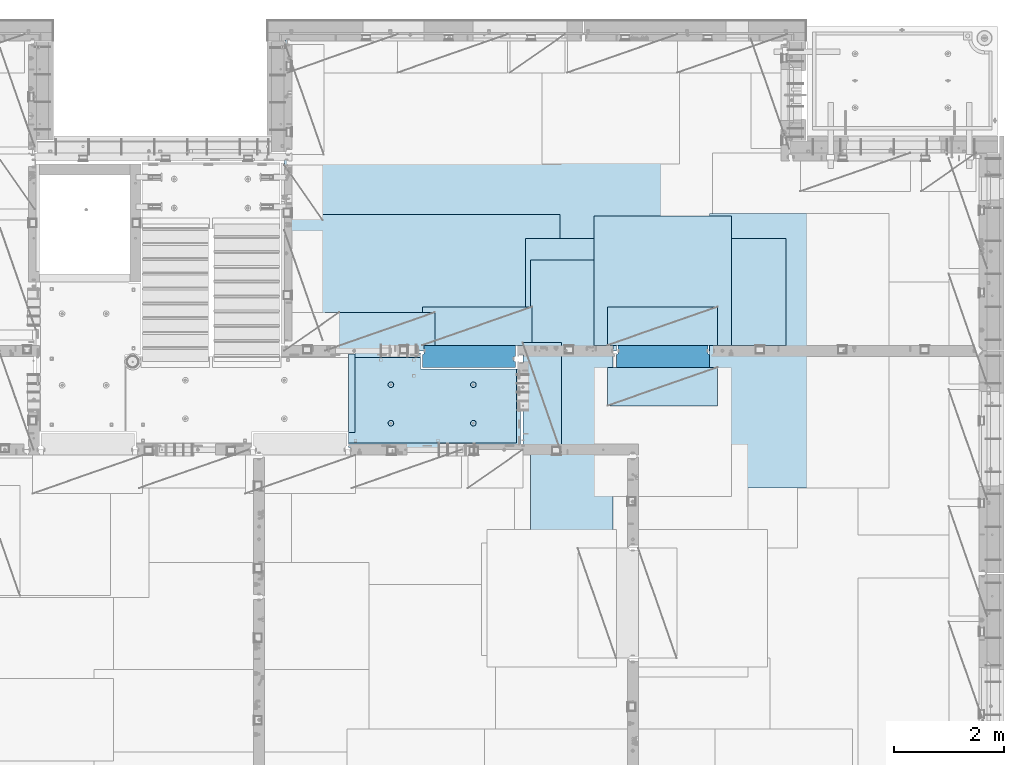
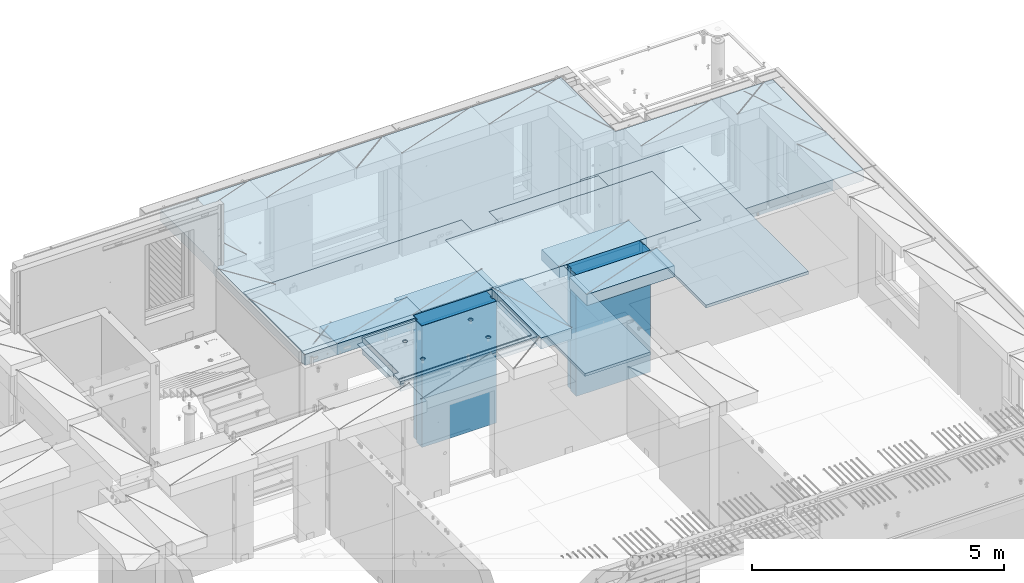
# One storey, part 209 of 349: 12 plates, 2 slabs, 13 elements without a shape of their own.
"""IFC2X3 building model written with IfcOpenShell, lengths in millimetres."""

from ifc_helpers import new_model, si_unit, frame, origin_with_axes, place, context, subcontext, project, spatial, faceted_brep, material, type_object, element, aggregate, save


model = new_model("IFC2X3")

# Units and contexts
model_context = context("Model", 3, precision=1e-05, world=origin_with_axes())
body_context = subcontext(model_context, "Body", "Model", "MODEL_VIEW")
ifc_project = project(units=[si_unit("LENGTHUNIT", "METRE", prefix="MILLI"), si_unit("AREAUNIT", "SQUARE_METRE"), si_unit("VOLUMEUNIT", "CUBIC_METRE"), si_unit("MASSUNIT", "GRAM", prefix="KILO"), si_unit("TIMEUNIT", "SECOND"), si_unit("PLANEANGLEUNIT", "RADIAN"), si_unit("SOLIDANGLEUNIT", "STERADIAN"), si_unit("THERMODYNAMICTEMPERATUREUNIT", "DEGREE_CELSIUS"), si_unit("LUMINOUSINTENSITYUNIT", "LUMEN")], contexts=[model_context])

# Site, building, storey
site_placement = place(None, origin_with_axes())
site = spatial("IfcSite", under=ifc_project, at=site_placement, CompositionType="ELEMENT")
building_placement = place(site_placement, origin_with_axes())
building = spatial("IfcBuilding", under=site, at=building_placement, CompositionType="ELEMENT")
storey_placement = place(building_placement, origin_with_axes())
storey = spatial("IfcBuildingStorey", under=building, at=storey_placement, Name="4", CompositionType="ELEMENT", Elevation=0.0)

# Assembly, slab
assembly_1_placement = place(storey_placement, origin_with_axes())
assembly_1 = element("IfcElementAssembly", 1, at=assembly_1_placement, inside=storey, AssemblyPlace="NOTDEFINED", PredefinedType="REINFORCEMENT_UNIT")
ifc_material_1 = material(Name="CONCRETE/C25/30")
slab_type_1 = type_object("IfcSlabType", PredefinedType="NOTDEFINED")
slab_1_placement = place(assembly_1_placement, frame((26570.0059390845, 15220.0026483125, 93620.0), z_axis=(-0.999999999997437, -2.26400000064461e-06, 0.0), x_axis=(-1.19799915409591e-06, 0.999999999999282, 0.0)))
slab_1 = element("IfcSlab", 2, at=slab_1_placement, type_object=slab_type_1, material=ifc_material_1, PredefinedType="FLOOR", context=body_context, shape_type="Brep", body=[
    faceted_brep([(260.000036693442, 30.0, 20.0001116859203), (260.00040878505, 30.0, 210.00282380305), (760.000392750888, 30.0, 210.001882803081), (760.000035167954, 30.0, 20.0003241859195), (259.999997532928, 50.0008466322761, 0.000110715616756352), (259.999997531775, 130.0, 4.72937244921923e-11), (260.00040878505, 130.0, 210.00282380305), (260.00003669344, 50.0008466322906, 20.0001116859239), (760.000392750888, 130.0, 210.001882803081), (759.999997530887, 50.0009701322706, 0.00188280345173553), (760.000035167954, 50.0009701322851, 20.0003241859267), (759.999997530887, 130.0, 1.4915713109076e-10), (0.0, 130.0, -1.81898940354586e-12), (0.0, 50.0007830199902, -3.63797880709171e-12), (2.23492861550767e-06, 50.0007830199902, 20.0000012144774), (0.00314200731554592, 50.0009709416772, 1679.99820316408), (0.00316042736994859, 130.0, 1679.99820316404), (20.0042037197236, 50.0007871208509, 20.0000019346335), (20.0050448999082, 50.0009732451872, 1679.9981655205), (20.0051981998968, 30.0, 1979.99816552074), (210.003723882246, 30.0, 1979.99780794351), (210.003159282247, 30.0, 1679.99780794404), (20.0050448999027, 30.0, 1679.9981655205), (20.0057858500695, 50.0011356208415, 3129.99855788155), (0.00588817475545511, 50.0011356208415, 3129.99536132812), (0.00371018100122456, 50.0010050132987, 1979.99820316354), (20.0051981998986, 50.0010068401461, 1979.99816552074), (1720.00727399273, -49.9988643791585, 3014.99216831216), (1700.0058891816, -49.9988643791585, 3014.99217713277), (1700.0058891816, 9.99999999994179, 3014.99217713277), (270.007273993393, 9.99999999994179, 3014.99280776216), (270.007273993393, -130.000000000058, 3014.99280776216), (1640.00591170533, -130.000000000058, 3014.99220359276), (1640.00591170533, -110.000000000058, 3014.99220359276), (1720.00727399273, -110.000000000058, 3014.99216831216), (1700.00578510373, 9.99999999994179, 3129.99536132812), (270.007324709519, 9.99999999994179, 3129.99536132812), (1700.00588013352, 9.99999999994179, 3024.99005271558), (270.007324709519, -130.0, 3129.99536132812), (0.0, -49.9992169800098, -3.63797880709171e-12), (1.81898940354586e-12, -110.000000000058, 0.0), (0.00588817475545511, -110.0, 3129.99536132812), (0.00588817475545511, -49.9988643791585, 3129.99536132812), (2.27349282795331e-05, -49.9992169800098, 20.000001214441), (40.0000000237706, -110.0, 0.00323799208854325), (40.0000056179106, -110.0, 80.000116817555), (80.0001648500238, -110.0, 80.0001140175445), (80.0058896111077, -110.0, 3129.99536132811), (80.0001648500238, -130.0, 80.0001140175445), (80.0058896111077, -130.0, 3129.99536132812), (458.262860973307, -110.000000000015, 813.90255309167), (472.201273869185, -110.000000000015, 821.004529187678), (483.262860973307, -110.000000000015, 832.066116291804), (490.364837069317, -110.000000000015, 846.004529187678), (492.812011254558, -110.000000000015, 861.455378906427), (490.364837069317, -110.000000000015, 876.906228625172), (483.262860973307, -110.000000000015, 890.844641521049), (472.201273869185, -110.000000000015, 901.906228625176), (458.262860973306, -110.000000000015, 909.008204721184), (442.81201125456, -110.000000000015, 911.455378906427), (427.361161535811, -110.000000000015, 909.008204721184), (413.422748639936, -110.000000000015, 901.906228625176), (402.361161535813, -110.000000000015, 890.844641521046), (395.259185439802, -110.000000000015, 876.906228625176), (392.81201125456, -110.000000000015, 861.455378906427), (395.259185439802, -110.000000000015, 846.004529187681), (402.361161535813, -110.000000000015, 832.0661162918), (413.422748639936, -110.000000000015, 821.004529187678), (427.361161535813, -110.000000000015, 813.90255309167), (442.812011254558, -110.000000000015, 811.455378906427), (458.965172324157, -130.0, 811.741061009179), (442.812011254558, -130.0, 809.182651633699), (473.537149442574, -130.0, 819.165854200462), (485.101535960521, -130.0, 830.730240718414), (492.526329151806, -130.0, 845.302217836826), (495.084738527285, -130.0, 861.45537890643), (492.526329151804, -130.0, 877.608539976027), (485.101535960521, -130.0, 892.180517094443), (473.537149442574, -130.0, 903.744903612387), (458.965172324157, -130.0, 911.16969680367), (442.81201125456, -130.0, 913.728106179151), (426.658850184962, -130.0, 911.169696803674), (412.086873066544, -130.0, 903.744903612391), (400.522486548598, -130.0, 892.180517094443), (393.097693357315, -130.0, 877.608539976027), (390.539283981834, -130.0, 861.455378906427), (393.097693357317, -130.0, 845.302217836826), (400.522486548598, -130.0, 830.730240718414), (412.086873066544, -130.0, 819.165854200462), (426.658850184962, -130.0, 811.741061009183), (1158.26361347154, -110.000000000058, 2313.90608356011), (1172.20202636741, -110.000000000058, 2321.00805965612), (1183.26361347154, -110.000000000058, 2332.06964676024), (1190.36558956755, -110.000000000058, 2346.00805965611), (1192.81276375279, -110.000000000058, 2361.45890937486), (1190.36558956755, -110.000000000058, 2376.90975909361), (1183.26361347154, -110.000000000058, 2390.84817198949), (1172.20202636741, -110.000000000058, 2401.90975909361), (1158.26361347154, -110.000000000058, 2409.01173518962), (1142.81276375279, -110.000000000058, 2411.45890937487), (1127.36191403404, -110.000000000058, 2409.01173518962), (1113.42350113817, -110.000000000058, 2401.90975909361), (1102.36191403404, -110.000000000058, 2390.84817198948), (1095.25993793803, -110.000000000058, 2376.90975909361), (1092.81276375279, -110.000000000058, 2361.45890937486), (1095.25993793803, -110.000000000058, 2346.00805965612), (1102.36191403404, -110.000000000058, 2332.06964676024), (1113.42350113817, -110.000000000058, 2321.00805965611), (1127.36191403405, -110.000000000058, 2313.90608356011), (1142.81276375279, -110.000000000058, 2311.45890937486), (1158.96592482239, -130.000000000044, 2311.74459147762), (1142.81276375279, -130.000000000044, 2309.18618210214), (1173.5379019408, -130.000000000044, 2319.1693846689), (1185.10228845875, -130.000000000044, 2330.73377118685), (1192.52708165004, -130.000000000044, 2345.30574830526), (1195.08549102551, -130.000000000044, 2361.45890937486), (1192.52708165004, -130.000000000044, 2377.61207044447), (1185.10228845875, -130.000000000044, 2392.18404756288), (1173.5379019408, -130.000000000044, 2403.74843408083), (1158.96592482239, -130.000000000044, 2411.17322727211), (1142.81276375279, -130.000000000044, 2413.73163664759), (1126.65960268319, -130.000000000044, 2411.17322727211), (1112.08762556478, -130.000000000044, 2403.74843408083), (1100.52323904683, -130.000000000044, 2392.18404756287), (1093.09844585554, -130.000000000044, 2377.61207044447), (1090.54003648007, -130.000000000044, 2361.45890937486), (1093.09844585555, -130.000000000044, 2345.30574830526), (1100.52323904683, -130.000000000044, 2330.73377118685), (1112.08762556478, -130.000000000044, 2319.1693846689), (1126.65960268319, -130.000000000044, 2311.74459147762), (1158.26322681425, -110.000000000029, 813.902566246979), (1172.20163971013, -110.000000000029, 821.004542342987), (1183.26322681425, -110.000000000029, 832.066129447114), (1190.36520291026, -110.000000000029, 846.004542342987), (1192.8123770955, -110.000000000029, 861.455392061736), (1190.36520291026, -110.000000000029, 876.906241780482), (1183.26322681425, -110.000000000029, 890.844654676363), (1172.20163971012, -110.000000000029, 901.906241780485), (1158.26322681425, -110.000000000029, 909.008217876493), (1142.8123770955, -110.000000000029, 911.455392061736), (1127.36152737675, -110.000000000029, 909.008217876493), (1113.42311448088, -110.000000000029, 901.906241780485), (1102.36152737675, -110.000000000029, 890.844654676359), (1095.25955128074, -110.000000000029, 876.906241780485), (1092.8123770955, -110.000000000029, 861.45539206174), (1095.25955128074, -110.000000000029, 846.004542342991), (1102.36152737675, -110.000000000029, 832.06612944711), (1113.42311448088, -110.000000000029, 821.004542342987), (1127.36152737675, -110.000000000029, 813.902566246979), (1142.8123770955, -110.000000000029, 811.455392061736), (1158.9655381651, -130.000000000029, 811.741074164489), (1142.8123770955, -130.000000000029, 809.182664789012), (1173.53751528352, -130.000000000029, 819.165867355772), (1185.10190180146, -130.000000000029, 830.730253873724), (1192.52669499275, -130.000000000029, 845.302230992136), (1195.08510436823, -130.000000000029, 861.45539206174), (1192.52669499275, -130.000000000029, 877.608553131337), (1185.10190180146, -130.000000000029, 892.180530249756), (1173.53751528351, -130.000000000029, 903.744916767697), (1158.9655381651, -130.000000000029, 911.16970995898), (1142.8123770955, -130.000000000029, 913.728119334461), (1126.6592160259, -130.000000000029, 911.169709958984), (1112.08723890749, -130.000000000029, 903.7449167677), (1100.52285238954, -130.000000000029, 892.180530249752), (1093.09805919825, -130.000000000029, 877.608553131337), (1090.53964982277, -130.000000000015, 861.455392061736), (1093.09805919826, -130.000000000015, 845.302230992136), (1100.52285238954, -130.000000000015, 830.730253873724), (1112.08723890749, -130.000000000015, 819.165867355776), (1126.6592160259, -130.000000000015, 811.741074164493), (458.263613472778, -110.000000000058, 2313.90740096011), (472.202026368655, -110.000000000058, 2321.00937705611), (483.263613472776, -110.000000000058, 2332.07096416024), (490.365589568788, -110.000000000058, 2346.00937705611), (492.812763754029, -110.000000000058, 2361.46022677486), (490.365589568788, -110.000000000058, 2376.91107649361), (483.263613472778, -110.000000000058, 2390.84948938949), (472.202026368655, -110.000000000058, 2401.91107649361), (458.263613472776, -110.000000000058, 2409.01305258962), (442.812763754029, -110.000000000058, 2411.46022677486), (427.361914035282, -110.000000000058, 2409.01305258962), (413.423501139407, -110.000000000058, 2401.91107649361), (402.361914035284, -110.000000000058, 2390.84948938949), (395.259937939272, -110.000000000058, 2376.91107649361), (392.812763754031, -110.000000000058, 2361.46022677486), (395.259937939272, -110.000000000058, 2346.00937705612), (402.361914035284, -110.000000000058, 2332.07096416024), (413.423501139407, -110.000000000058, 2321.00937705611), (427.361914035284, -110.000000000058, 2313.90740096011), (442.812763754029, -110.000000000058, 2311.46022677486), (458.965924823628, -130.000000000029, 2311.74590887762), (442.812763754029, -130.000000000029, 2309.18749950214), (473.537901942043, -130.000000000029, 2319.1707020689), (485.10228845999, -130.000000000029, 2330.73508858685), (492.527081651273, -130.000000000029, 2345.30706570526), (495.085491026754, -130.000000000029, 2361.46022677486), (492.527081651273, -130.000000000029, 2377.61338784446), (485.102288459992, -130.000000000029, 2392.18536496288), (473.537901942043, -130.000000000029, 2403.74975148082), (458.965924823628, -130.000000000029, 2411.1745446721), (442.812763754031, -130.000000000029, 2413.73295404758), (426.659602684433, -130.000000000029, 2411.17454467211), (412.087625566017, -130.000000000029, 2403.74975148082), (400.523239048071, -130.000000000029, 2392.18536496288), (393.098445856787, -130.000000000029, 2377.61338784446), (390.540036481307, -130.000000000029, 2361.46022677486), (393.098445856789, -130.000000000029, 2345.30706570526), (400.523239048067, -130.000000000029, 2330.73508858685), (412.087625566017, -130.000000000029, 2319.17070206891), (426.659602684433, -130.000000000029, 2311.74590887762), (1640.0069692709, -130.000000000058, 1820.00285259458), (1429.99412576448, -130.0, 80.0005450159842), (1430.00077693619, -130.000000000044, 1820.00324782623), (1640.0069692709, -110.000000000058, 1820.00285259458), (1720.00719314726, -110.000000000058, 1820.00270203416), (1720.00719416424, -49.9988643791585, 1820.00270203415), (1700.00697064704, -49.9988643791585, 1820.00273967458), (1430.00077693619, 129.999999999985, 1820.00324782623), (1720.00507313573, 130.0, 1820.00270203815), (1720.00696350816, 50.0011356208415, 1820.00270203459), (1700.00697064704, 50.0011356208415, 1820.00273967458), (1720.00548380367, 130.0, 2629.9953613439), (1720.00479630696, 50.0011356208415, 2629.99536134425), (1700.00623760369, 50.0011356208415, 2629.99539898154), (1700.00623760369, 30.0, 2629.99539898154), (1700.00578510373, 30.0, 3129.99535793147), (1510.00479630733, 130.0, 2629.99575656425), (1510.00479630733, 30.0, 2629.99575656425), (1510.00573730659, 130.0, 3129.99536132812), (1510.00573730659, 30.0, 3129.99536134176), (0.00588817475545511, 130.0, 3129.99536132812), (20.0057858500695, -49.9988643791585, 3129.99855788155), (0.00372479000361636, 130.0, 1979.99820316351), (210.003723882246, 130.0, 1979.99780794351), (210.003159282247, 130.0, 1679.99780794404), (20.0042037196527, -49.9988643791585, 20.0000019345935), (20.0041864226587, -49.9992128791491, 7.34271452529356e-07), (1429.99419217423, -49.9988643791585, 20.0006089333838), (1429.99420067423, -49.9988643791585, 0.000608933383773547), (80.0000146155362, -110.0, 0.000114017555461032), (1429.99735169022, -110.0, 7.40013310860377e-05), (1429.99412576448, -110.0, 80.0005450159842), (1429.99416747423, 50.0011356208415, 20.0006089334311), (1429.99417597423, 50.0011356208415, 0.000608933431067271), (1429.99735169022, 130.0, 2.80124368146062e-10), (20.0041864225386, 50.0007871208509, -3.03407432511449e-09)], [[[0, 1, 2, 3]], [[4, 5, 6, 1, 0, 7]], [[8, 2, 1, 6]], [[9, 10, 3, 2, 8, 11]], [[12, 13, 14, 15, 16]], [[14, 17, 18, 15]], [[19, 20, 21, 22]], [[23, 24, 25, 26]], [[27, 28, 29, 30, 31, 32, 33, 34]], [[35, 36, 30, 29, 37]], [[31, 30, 36, 38]], [[39, 40, 41, 42, 43]], [[44, 45, 46, 47, 41, 40]], [[48, 49, 47, 46]], [[50, 51, 52, 53, 54, 55, 56, 57, 58, 59, 60, 61, 62, 63, 64, 65, 66, 67, 68, 69]], [[70, 50, 69, 71]], [[72, 51, 50, 70]], [[73, 52, 51, 72]], [[74, 53, 52, 73]], [[75, 54, 53, 74]], [[76, 55, 54, 75]], [[77, 56, 55, 76]], [[78, 57, 56, 77]], [[79, 58, 57, 78]], [[80, 59, 58, 79]], [[81, 60, 59, 80]], [[82, 61, 60, 81]], [[83, 62, 61, 82]], [[84, 63, 62, 83]], [[85, 64, 63, 84]], [[86, 65, 64, 85]], [[87, 66, 65, 86]], [[88, 67, 66, 87]], [[89, 68, 67, 88]], [[71, 69, 68, 89]], [[90, 91, 92, 93, 94, 95, 96, 97, 98, 99, 100, 101, 102, 103, 104, 105, 106, 107, 108, 109]], [[110, 90, 109, 111]], [[112, 91, 90, 110]], [[113, 92, 91, 112]], [[114, 93, 92, 113]], [[115, 94, 93, 114]], [[116, 95, 94, 115]], [[117, 96, 95, 116]], [[118, 97, 96, 117]], [[119, 98, 97, 118]], [[120, 99, 98, 119]], [[121, 100, 99, 120]], [[122, 101, 100, 121]], [[123, 102, 101, 122]], [[124, 103, 102, 123]], [[125, 104, 103, 124]], [[126, 105, 104, 125]], [[127, 106, 105, 126]], [[128, 107, 106, 127]], [[129, 108, 107, 128]], [[111, 109, 108, 129]], [[130, 131, 132, 133, 134, 135, 136, 137, 138, 139, 140, 141, 142, 143, 144, 145, 146, 147, 148, 149]], [[150, 130, 149, 151]], [[152, 131, 130, 150]], [[153, 132, 131, 152]], [[154, 133, 132, 153]], [[155, 134, 133, 154]], [[156, 135, 134, 155]], [[157, 136, 135, 156]], [[158, 137, 136, 157]], [[159, 138, 137, 158]], [[160, 139, 138, 159]], [[161, 140, 139, 160]], [[162, 141, 140, 161]], [[163, 142, 141, 162]], [[164, 143, 142, 163]], [[165, 144, 143, 164]], [[166, 145, 144, 165]], [[167, 146, 145, 166]], [[168, 147, 146, 167]], [[169, 148, 147, 168]], [[151, 149, 148, 169]], [[170, 171, 172, 173, 174, 175, 176, 177, 178, 179, 180, 181, 182, 183, 184, 185, 186, 187, 188, 189]], [[190, 170, 189, 191]], [[192, 171, 170, 190]], [[193, 172, 171, 192]], [[194, 173, 172, 193]], [[195, 174, 173, 194]], [[196, 175, 174, 195]], [[197, 176, 175, 196]], [[198, 177, 176, 197]], [[199, 178, 177, 198]], [[200, 179, 178, 199]], [[201, 180, 179, 200]], [[202, 181, 180, 201]], [[203, 182, 181, 202]], [[204, 183, 182, 203]], [[205, 184, 183, 204]], [[206, 185, 184, 205]], [[207, 186, 185, 206]], [[208, 187, 186, 207]], [[209, 188, 187, 208]], [[191, 189, 188, 209]], [[210, 32, 31, 38, 49, 48, 211, 212], [208, 207, 206, 205, 204, 203, 202, 201, 200, 199, 198, 197, 196, 195, 194, 193, 192, 190, 191, 209], [168, 167, 166, 165, 164, 163, 162, 161, 160, 159, 158, 157, 156, 155, 154, 153, 152, 150, 151, 169], [128, 127, 126, 125, 124, 123, 122, 121, 120, 119, 118, 117, 116, 115, 114, 113, 112, 110, 111, 129], [88, 87, 86, 85, 84, 83, 82, 81, 80, 79, 78, 77, 76, 75, 74, 73, 72, 70, 71, 89]], [[33, 32, 210, 213]], [[34, 33, 213, 214]], [[27, 34, 214, 215]], [[28, 27, 215, 216]], [[214, 213, 210, 212, 217, 218, 219, 220, 216, 215]], [[219, 218, 221, 222]], [[220, 219, 222, 223]], [[35, 37, 29, 28, 216, 220, 223, 224, 225]], [[222, 221, 226, 227, 224, 223]], [[228, 229, 227, 226]], [[224, 227, 229, 225]], [[228, 230, 24, 23, 231, 42, 41, 47, 49, 38, 36, 35, 225, 229]], [[24, 230, 232, 25]], [[233, 20, 19, 26, 25, 232]], [[234, 21, 20, 233]], [[16, 15, 18, 22, 21, 234]], [[17, 235, 231, 23, 26, 19, 22, 18]], [[43, 42, 231, 235]], [[236, 39, 43, 235, 237, 238]], [[239, 44, 40, 39, 236, 238, 240]], [[46, 45, 44, 239, 240, 241]], [[48, 46, 241, 211]], [[240, 238, 237, 242, 243, 244, 217, 212, 211, 241]], [[244, 243, 9, 11]], [[6, 5, 12, 16, 234, 233, 232, 230, 228, 226, 221, 218, 217, 244, 11, 8]], [[245, 13, 12, 5, 4]], [[17, 14, 13, 245, 4, 7]], [[242, 237, 235, 17, 7, 0, 3, 10]], [[243, 242, 10, 9]]]),
])
aggregate(assembly_1, [slab_1])

assembly_2_placement = place(storey_placement, origin_with_axes())
assembly_2 = element("IfcElementAssembly", 3, at=assembly_2_placement, inside=storey, AssemblyPlace="NOTDEFINED", PredefinedType="REINFORCEMENT_UNIT")
ifc_material_2 = material(Name="CONCRETE/C30/37")
slab_type_2 = type_object("IfcSlabType", PredefinedType="NOTDEFINED")
slab_2_placement = place(assembly_2_placement, frame((22310.0, 16980.0, 93595.0), z_axis=(0.0, 1.0, 0.0), x_axis=(1.0, 0.0, 0.0)))
slab_2 = element("IfcSlab", 4, at=slab_2_placement, type_object=slab_type_2, material=ifc_material_2, PredefinedType="FLOOR", context=body_context, shape_type="Brep", body=[
    faceted_brep([(4369.99914550782, -135.0, 99.9999987875526), (4369.99914550782, 135.0, 99.9999987875526), (4369.99914550782, 135.0, 0.0), (4369.99914550782, -135.0, 0.0), (4169.99914550781, -135.0, 99.9997253417969), (4169.99914550781, 135.0, 99.9997253417969), (2489.99914550781, -135.0, 0.0), (2489.99914550781, 135.0, 0.0), (2489.99914550781, 135.0, 99.9997253417969), (2489.99914550781, -135.0, 99.9997253417969), (1.81898940354586e-12, -135.0, 1.81898940354586e-12), (1.81898940354586e-12, 135.0, 1.81898940354586e-12), (-39.9985427856445, -135.0, -0.0037095642182976), (-39.9985427856445, 135.0, -0.0037095642182976), (-40.0, -135.0, 3600.00048828125), (-40.0, 135.0, 3600.00048828125), (-20.0, -135.0, 3600.0), (-20.0, 135.0, 3600.0), (-20.0, -135.0, 5760.0), (-20.0, 135.0, 5760.0), (9149.9990234375, -135.0, 5760.0), (9149.9990234375, 135.0, 5760.0), (9149.9990234375, -135.0, 3600.00073242188), (9149.9990234375, 135.0, 3600.00073242188), (12750.0, -135.0, 3599.9951171875), (12750.0, 135.0, 3599.9951171875), (12750.0, -135.0, 0.0), (12750.0, 135.0, 0.0), (7685.0006429507, -135.0, 0.0), (7685.0006429507, 135.0, 0.0), (7685.0006429507, -135.0, 99.9996630941932), (7685.0006429507, 135.0, 99.9996630941932), (5999.99954431789, -135.0, 99.9996630941932), (5999.99954431789, 135.0, 99.9996630941932), (5999.99954431789, -135.0, 0.0), (5999.99954431789, 135.0, 0.0), (2730.00000000001, 135.0, 99.9997253417969), (2730.00000000001, -135.0, 99.9997253417969)], [[[0, 1, 2, 3]], [[4, 5, 1, 0]], [[6, 7, 8, 9]], [[10, 11, 7, 6]], [[10, 12, 13, 11]], [[12, 14, 15, 13]], [[14, 16, 17, 15]], [[16, 18, 19, 17]], [[18, 20, 21, 19]], [[20, 22, 23, 21]], [[22, 24, 25, 23]], [[24, 26, 27, 25]], [[27, 26, 28, 29]], [[30, 31, 29, 28]], [[32, 33, 31, 30]], [[34, 35, 33, 32]], [[35, 34, 3, 2]], [[36, 8, 7, 11, 13, 15, 17, 19, 21, 23, 25, 27, 29, 31, 33, 35, 2, 1, 5]], [[37, 9, 8, 36, 5, 4]], [[34, 32, 30, 28, 26, 24, 22, 20, 18, 16, 14, 12, 10, 6, 9, 37, 4, 0, 3]]]),
])

# Assembly, plate
assembly_3_placement = place(storey_placement, origin_with_axes())
assembly_3 = element("IfcElementAssembly", 5, at=assembly_3_placement, inside=storey, Name="Steel Assembly", AssemblyPlace="NOTDEFINED", PredefinedType="NOTDEFINED")
ifc_material_3 = material()
plate_type_1 = type_object("IfcPlateType", PredefinedType="NOTDEFINED")
plate_1_placement = place(assembly_3_placement, frame((22289.9998779297, 19460.0009765625, 93695.1), z_axis=(1.0, 0.0, 0.0), x_axis=(0.0, -1.0, 0.0)))
plate_1 = element("IfcPlate", 6, at=plate_1_placement, type_object=plate_type_1, material=ifc_material_3, context=body_context, shape_type="Brep", body=[
    faceted_brep([(0.0, -35.0, 0.0), (0.0, -35.0, 5000.0), (0.0, 35.0, 5000.0), (0.0, 35.0, 0.0), (2349.99951171875, -35.0, 5000.0), (2349.99951171875, 35.0, 5000.0), (2350.0, -35.0, 0.0), (2350.0, 35.0, 0.0)], [[[0, 1, 2, 3]], [[1, 4, 5, 2]], [[4, 6, 7, 5]], [[6, 0, 3, 7]], [[5, 7, 3, 2]], [[6, 4, 1, 0]]]),
])
aggregate(assembly_3, [plate_1])

assembly_4_placement = place(storey_placement, origin_with_axes())
assembly_4 = element("IfcElementAssembly", 7, at=assembly_4_placement, inside=storey, Name="Steel Assembly", AssemblyPlace="NOTDEFINED", PredefinedType="NOTDEFINED")
plate_2_placement = place(assembly_4_placement, frame((27902.5, 19430.0, 93695.1), z_axis=(1.0, 0.0, 0.0), x_axis=(0.0, -1.0, 0.0)))
plate_2 = element("IfcPlate", 8, at=plate_2_placement, type_object=plate_type_1, material=ifc_material_3, Name="1/2", context=body_context, shape_type="Brep", body=[
    faceted_brep([(0.0, -35.0, 0.0), (0.0, -35.0, 2500.0), (0.0, 35.0, 2500.0), (0.0, 35.0, 0.0), (2349.99951171875, -35.0, 2500.0), (2349.99951171875, 35.0, 2500.0), (2350.0, -35.0, 0.0), (2350.0, 35.0, 0.0)], [[[0, 1, 2, 3]], [[1, 4, 5, 2]], [[4, 6, 7, 5]], [[6, 0, 3, 7]], [[5, 7, 3, 2]], [[6, 4, 1, 0]]]),
])
aggregate(assembly_4, [plate_2])

assembly_5_placement = place(storey_placement, origin_with_axes())
assembly_5 = element("IfcElementAssembly", 9, at=assembly_5_placement, inside=storey, Name="Steel Assembly", AssemblyPlace="NOTDEFINED", PredefinedType="NOTDEFINED")
plate_3_placement = place(assembly_5_placement, frame((32360.0, 19480.0, 93695.1), z_axis=(0.0, -1.0, 0.0), x_axis=(-1.0, 3.00000001838171e-08, 0.0)))
plate_3 = element("IfcPlate", 10, at=plate_3_placement, type_object=plate_type_1, material=ifc_material_3, context=body_context, shape_type="Brep", body=[
    faceted_brep([(0.0, -35.0, 0.0), (0.0, -35.0, 5000.0), (0.0, 35.0, 5000.0), (0.0, 35.0, 0.0), (2349.99951171875, -35.0, 5000.0), (2349.99951171875, 35.0, 5000.0), (2350.0, -35.0, 0.0), (2350.0, 35.0, 0.0)], [[[0, 1, 2, 3]], [[1, 4, 5, 2]], [[4, 6, 7, 5]], [[6, 0, 3, 7]], [[5, 7, 3, 2]], [[6, 4, 1, 0]]]),
])
aggregate(assembly_5, [plate_3])

assembly_6_placement = place(storey_placement, origin_with_axes())
assembly_6 = element("IfcElementAssembly", 11, at=assembly_6_placement, inside=storey, Name="Steel Assembly", AssemblyPlace="NOTDEFINED", PredefinedType="NOTDEFINED")
plate_type_2 = type_object("IfcPlateType", PredefinedType="NOTDEFINED")
plate_4_placement = place(assembly_6_placement, frame((28250.0000122641, 18630.0, 93695.1000003815), z_axis=(0.0, -1.0, 0.0), x_axis=(-1.0, 3.00000001838171e-08, 0.0)))
plate_4 = element("IfcPlate", 12, at=plate_4_placement, type_object=plate_type_2, material=ifc_material_3, context=body_context, shape_type="Brep", body=[
    faceted_brep([(0.0, -35.0, 0.0), (0.0, -35.0, 5000.0), (0.0, 35.0, 5000.0), (0.0, 35.0, 0.0), (1499.99951171875, -35.0, 5000.0), (1499.99951171875, 35.0, 5000.0), (1500.0, -35.0, 0.0), (1500.0, 35.0, 0.0)], [[[0, 1, 2, 3]], [[1, 4, 5, 2]], [[4, 6, 7, 5]], [[6, 0, 3, 7]], [[5, 7, 3, 2]], [[6, 4, 1, 0]]]),
])
aggregate(assembly_6, [plate_4])

assembly_7_placement = place(storey_placement, origin_with_axes())
assembly_7 = element("IfcElementAssembly", 13, at=assembly_7_placement, inside=storey, Name="Steel Assembly", AssemblyPlace="NOTDEFINED", PredefinedType="NOTDEFINED")
plate_type_3 = type_object("IfcPlateType", PredefinedType="NOTDEFINED")
plate_5_placement = place(assembly_7_placement, frame((23010.0008542386, 16980.0001036336, 93595.3), z_axis=(0.0, 1.0, 0.0), x_axis=(1.0, 0.0, 0.0)))
plate_5 = element("IfcPlate", 14, at=plate_5_placement, type_object=plate_type_3, material=ifc_material_3, Name="RE1", context=body_context, shape_type="Brep", body=[
    faceted_brep([(1.81898940354586e-12, -135.0, 1.81898940354586e-12), (0.0, -135.0, 699.999999999996), (0.0, 135.0, 699.999999999996), (1.81898940354586e-12, 135.0, 1.81898940354586e-12), (1999.99951171875, -135.0, 699.999999999993), (1999.99951171875, 135.0, 699.999999999993), (2000.0, -135.0, -3.63797880709171e-12), (2000.0, 135.0, -3.63797880709171e-12)], [[[0, 1, 2, 3]], [[1, 4, 5, 2]], [[4, 6, 7, 5]], [[6, 0, 3, 7]], [[5, 7, 3, 2]], [[6, 4, 1, 0]]]),
])
aggregate(assembly_7, [plate_5])

assembly_8_placement = place(storey_placement, origin_with_axes())
assembly_8 = element("IfcElementAssembly", 15, at=assembly_8_placement, inside=storey, Name="Steel Assembly", AssemblyPlace="NOTDEFINED", PredefinedType="NOTDEFINED")
plate_6_placement = place(assembly_8_placement, frame((30152.4991457614, 16679.9998963664, 93595.3), z_axis=(0.0, -1.0, 0.0), x_axis=(-1.0, 3.00000001838171e-08, 0.0)))
plate_6 = element("IfcPlate", 16, at=plate_6_placement, type_object=plate_type_3, material=ifc_material_3, Name="RE1", context=body_context, shape_type="Brep", body=[
    faceted_brep([(1.81898940354586e-12, -135.0, 1.81898940354586e-12), (0.0, -135.0, 699.999999999996), (0.0, 135.0, 699.999999999996), (1.81898940354586e-12, 135.0, 1.81898940354586e-12), (1999.99951171875, -135.0, 699.999999999993), (1999.99951171875, 135.0, 699.999999999993), (2000.0, -135.0, -3.63797880709171e-12), (2000.0, 135.0, -3.63797880709171e-12)], [[[0, 1, 2, 3]], [[1, 4, 5, 2]], [[4, 6, 7, 5]], [[6, 0, 3, 7]], [[5, 7, 3, 2]], [[6, 4, 1, 0]]]),
])
aggregate(assembly_8, [plate_6])

assembly_9_placement = place(storey_placement, origin_with_axes())
assembly_9 = element("IfcElementAssembly", 17, at=assembly_9_placement, inside=storey, Name="Steel Assembly", AssemblyPlace="NOTDEFINED", PredefinedType="NOTDEFINED")
plate_7_placement = place(assembly_9_placement, frame((28152.5008542386, 17080.0001036336, 93595.3), z_axis=(0.0, 1.0, 0.0), x_axis=(1.0, 0.0, 0.0)))
plate_7 = element("IfcPlate", 18, at=plate_7_placement, type_object=plate_type_3, material=ifc_material_3, Name="RE1", context=body_context, shape_type="Brep", body=[
    faceted_brep([(1.81898940354586e-12, -135.0, 1.81898940354586e-12), (0.0, -135.0, 699.999999999996), (0.0, 135.0, 699.999999999996), (1.81898940354586e-12, 135.0, 1.81898940354586e-12), (1999.99951171875, -135.0, 699.999999999993), (1999.99951171875, 135.0, 699.999999999993), (2000.0, -135.0, -3.63797880709171e-12), (2000.0, 135.0, -3.63797880709171e-12)], [[[0, 1, 2, 3]], [[1, 4, 5, 2]], [[4, 6, 7, 5]], [[6, 0, 3, 7]], [[5, 7, 3, 2]], [[6, 4, 1, 0]]]),
])
aggregate(assembly_9, [plate_7])

assembly_10_placement = place(storey_placement, origin_with_axes())
assembly_10 = element("IfcElementAssembly", 19, at=assembly_10_placement, inside=storey, Name="Steel Assembly", AssemblyPlace="NOTDEFINED", PredefinedType="NOTDEFINED")
plate_8_placement = place(assembly_10_placement, frame((24780.0008542386, 17080.0001036336, 93595.3), z_axis=(0.0, 1.0, 0.0), x_axis=(1.0, 0.0, 0.0)))
plate_8 = element("IfcPlate", 20, at=plate_8_placement, type_object=plate_type_3, material=ifc_material_3, Name="RE1", context=body_context, shape_type="Brep", body=[
    faceted_brep([(1.81898940354586e-12, -135.0, 1.81898940354586e-12), (0.0, -135.0, 699.999999999996), (0.0, 135.0, 699.999999999996), (1.81898940354586e-12, 135.0, 1.81898940354586e-12), (1999.99951171875, -135.0, 699.999999999993), (1999.99951171875, 135.0, 699.999999999993), (2000.0, -135.0, -3.63797880709171e-12), (2000.0, 135.0, -3.63797880709171e-12)], [[[0, 1, 2, 3]], [[1, 4, 5, 2]], [[4, 6, 7, 5]], [[6, 0, 3, 7]], [[5, 7, 3, 2]], [[6, 4, 1, 0]]]),
])
aggregate(assembly_10, [plate_8])

assembly_11_placement = place(storey_placement, origin_with_axes())
assembly_11 = element("IfcElementAssembly", 21, at=assembly_11_placement, inside=storey, Name="Steel Assembly", AssemblyPlace="NOTDEFINED", PredefinedType="NOTDEFINED")
plate_9_placement = place(assembly_11_placement, frame((26609.9998779297, 17130.0, 93595.3), z_axis=(1.0, 0.0, 0.0), x_axis=(0.0, -1.0, 0.0)))
plate_9 = element("IfcPlate", 22, at=plate_9_placement, type_object=plate_type_3, material=ifc_material_3, Name="RE1", context=body_context, shape_type="Brep", body=[
    faceted_brep([(1.81898940354586e-12, -135.0, 1.81898940354586e-12), (0.0, -135.0, 699.999999999996), (0.0, 135.0, 699.999999999996), (1.81898940354586e-12, 135.0, 1.81898940354586e-12), (1999.99951171875, -135.0, 699.999999999993), (1999.99951171875, 135.0, 699.999999999993), (2000.0, -135.0, -3.63797880709171e-12), (2000.0, 135.0, -3.63797880709171e-12)], [[[0, 1, 2, 3]], [[1, 4, 5, 2]], [[4, 6, 7, 5]], [[6, 0, 3, 7]], [[5, 7, 3, 2]], [[6, 4, 1, 0]]]),
])
aggregate(assembly_11, [plate_9])

# Plate
plate_type_4 = type_object("IfcPlateType", PredefinedType="NOTDEFINED")
plate_10_placement = place(assembly_2_placement, frame((31402.0004441066, 19019.9993561238, 93725.45), z_axis=(0.0, -1.0, 0.0), x_axis=(-1.0, 3.00000001838171e-08, 0.0)))
plate_10 = element("IfcPlate", 23, at=plate_10_placement, type_object=plate_type_4, material=ifc_material_3, context=body_context, shape_type="Brep", body=[
    faceted_brep([(0.0, -5.0, 0.0), (0.0, -5.0, 1939.99963378906), (0.0, 5.0, 1939.99963378906), (0.0, 5.0, 0.0), (4742.00048828125, -5.0, 1939.99963378906), (4742.00048828125, 5.0, 1939.99963378906), (4742.00048828125, -5.0, 0.0), (4742.00048828125, 5.0, 0.0), (92.0009613037109, -5.0, 0.0), (92.0009613037109, 5.0, 0.0)], [[[0, 1, 2, 3]], [[1, 4, 5, 2]], [[4, 6, 7, 5]], [[6, 8, 9, 7]], [[8, 0, 3, 9]], [[5, 7, 9, 3, 2]], [[8, 6, 4, 1, 0]]]),
])

aggregate(assembly_2, [plate_10, slab_2])

# Assembly, plate
assembly_12_placement = place(storey_placement, origin_with_axes())
assembly_12 = element("IfcElementAssembly", 24, at=assembly_12_placement, inside=storey, Name="Steel Assembly", AssemblyPlace="NOTDEFINED", PredefinedType="NOTDEFINED")
ifc_material_4 = material()
plate_type_5 = type_object("IfcPlateType", PredefinedType="NOTDEFINED")
plate_11_placement = place(assembly_12_placement, frame((24780.0, 16680.0, 92255.6000003815), z_axis=(0.0, 1.0, 0.0), x_axis=(1.0, 0.0, 0.0)))
plate_11 = element("IfcPlate", 25, at=plate_11_placement, type_object=plate_type_5, material=ifc_material_4, context=body_context, shape_type="Brep", body=[
    faceted_brep([(1699.99914550781, -1475.0, 110.0), (1699.99914550781, 1475.0, 110.0), (1669.99914550781, 1475.0, 110.0), (1669.99914550781, -1475.00000000001, 110.0), (1669.99914550781, 1475.0, 200.0), (1669.99914550781, -1475.00000000001, 200.0), (1699.99914550781, -1475.0, 200.0), (1699.99914550781, 1475.0, 200.0), (1699.99914550781, -1475.0, 3.63797880709171e-12), (0.0, -1475.0, 0.0), (0.0, 1475.0, 0.0), (1699.99914550781, 1475.0, 3.63797880709171e-12), (0.0, -1475.0, 230.0), (0.0, 1475.0, 230.0), (30.0, -1475.0, 243.0), (30.0, 1475.0, 243.0), (30.0, -1475.0, 400.0), (30.0, 1475.0, 400.0), (1699.99914550781, -1475.0, 400.0), (1699.99914550781, 1475.0, 400.0)], [[[0, 1, 2, 3]], [[3, 2, 4, 5]], [[6, 5, 4, 7]], [[8, 9, 10, 11]], [[10, 9, 12, 13]], [[14, 15, 13, 12]], [[16, 17, 15, 14]], [[18, 19, 17, 16]], [[19, 18, 6, 7]], [[2, 1, 11, 10, 13, 15, 17, 19, 7, 4]], [[8, 11, 1, 0]], [[18, 16, 14, 12, 9, 8, 0, 3, 5, 6]]]),
])
aggregate(assembly_12, [plate_11])

assembly_13_placement = place(storey_placement, origin_with_axes())
assembly_13 = element("IfcElementAssembly", 26, at=assembly_13_placement, inside=storey, Name="Steel Assembly", AssemblyPlace="NOTDEFINED", PredefinedType="NOTDEFINED")
plate_12_placement = place(assembly_13_placement, frame((28309.9999105288, 16680.0000293051, 92255.6000003815), z_axis=(0.0, 1.0, 0.0), x_axis=(1.0, 0.0, 0.0)))
plate_12 = element("IfcPlate", 27, at=plate_12_placement, type_object=plate_type_5, material=ifc_material_4, context=body_context, shape_type="Brep", body=[
    faceted_brep([(29.9999989126591, -1475.0, 243.000885767418), (29.9999989126591, 1475.0, 243.000885767418), (0.0, 1475.0, 230.000886222213), (0.0, -1475.0, 230.000886222213), (30.0000025741901, -1475.0, 399.999635204884), (30.0000025741901, 1475.0, 399.999633789063), (1700.00073242188, -1475.0, 0.0), (0.0, -1475.0, 0.0), (0.0, 1475.0, 0.0), (1700.00073242188, 1475.0, 0.0), (1700.00073242188, 1475.0, 230.001129150391), (1700.00041094652, -1475.0, 230.001129150391), (1670.00041094652, 1475.0, 243.001129150391), (1670.00041094652, -1475.0, 243.001129150391), (1670.00041094652, -1475.0, 399.999633789063), (1670.00041094652, 1475.0, 399.999633789063)], [[[0, 1, 2, 3]], [[4, 5, 1, 0]], [[6, 7, 8, 9]], [[6, 9, 10, 11]], [[11, 10, 12, 13]], [[14, 13, 12, 15]], [[3, 7, 6, 11, 13, 14, 4, 0]], [[8, 7, 3, 2]], [[15, 12, 10, 9, 8, 2, 1, 5]], [[14, 15, 5, 4]]]),
])
aggregate(assembly_13, [plate_12])

save(model, "model.ifc")
